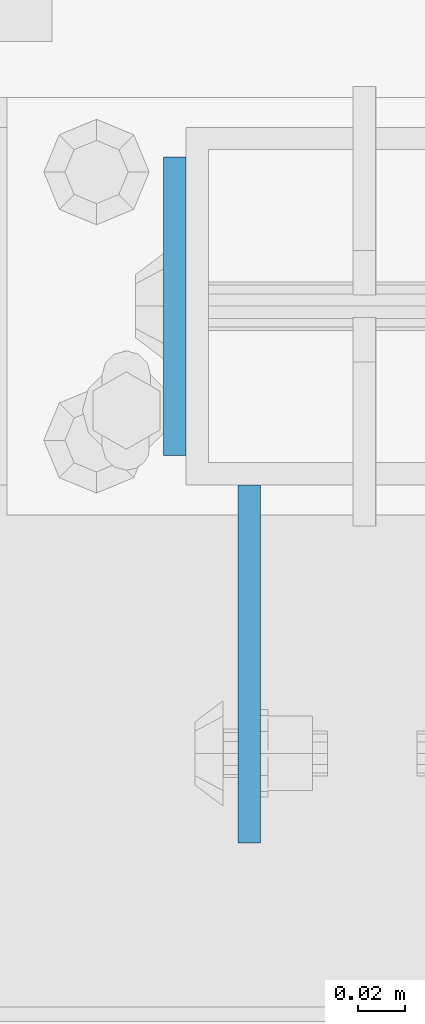
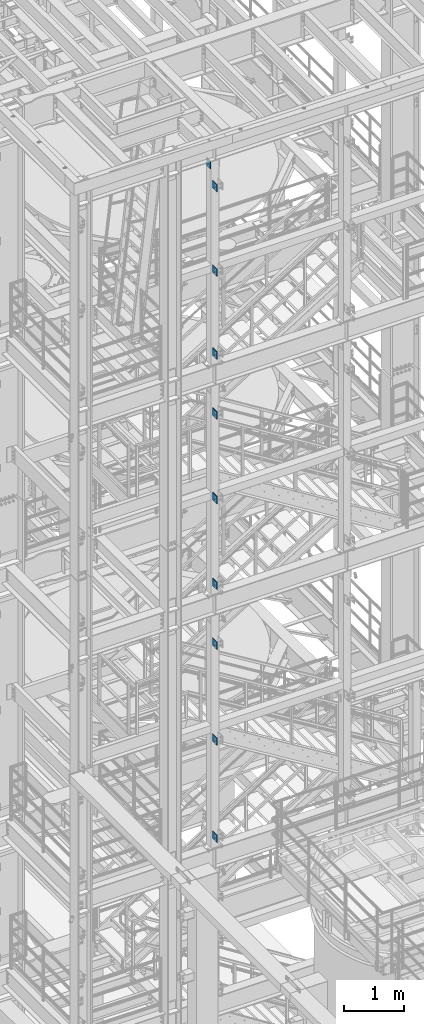
# One storey, part 1127 of 1876: 10 beams, 4 elements without a shape of their own.
"""IFC2X3 building model written with IfcOpenShell, lengths in millimetres."""

from ifc_helpers import new_model, si_unit, frame, origin_with_axes, place, context, subcontext, project, spatial, faceted_brep, material, type_object, element, aggregate, save


model = new_model("IFC2X3")

# Units and contexts
model_context = context("Model", 3, precision=1e-05, world=origin_with_axes())
body_context = subcontext(model_context, "Body", "Model", "MODEL_VIEW")
ifc_project = project(units=[si_unit("LENGTHUNIT", "METRE", prefix="MILLI"), si_unit("AREAUNIT", "SQUARE_METRE"), si_unit("VOLUMEUNIT", "CUBIC_METRE"), si_unit("MASSUNIT", "GRAM", prefix="KILO"), si_unit("TIMEUNIT", "SECOND"), si_unit("PLANEANGLEUNIT", "RADIAN"), si_unit("SOLIDANGLEUNIT", "STERADIAN"), si_unit("THERMODYNAMICTEMPERATUREUNIT", "DEGREE_CELSIUS"), si_unit("LUMINOUSINTENSITYUNIT", "LUMEN")], contexts=[model_context])

# Site, building, storey
site_placement = place(None, origin_with_axes())
site = spatial("IfcSite", under=ifc_project, at=site_placement, CompositionType="ELEMENT")
building_placement = place(site_placement, origin_with_axes())
building = spatial("IfcBuilding", under=site, at=building_placement, Name="Undefined", CompositionType="ELEMENT")
storey_placement = place(building_placement, origin_with_axes())
storey = spatial("IfcBuildingStorey", under=building, at=storey_placement, Name="Undefined", CompositionType="ELEMENT", Elevation=0.0)

# Assembly, beams
assembly_1_placement = place(storey_placement, origin_with_axes())
assembly_1 = element("IfcElementAssembly", 1, at=assembly_1_placement, inside=storey, Name="FRAME", AssemblyPlace="NOTDEFINED", PredefinedType="RIGID_FRAME")
ifc_material = material(Name="STEEL/A36")
beam_type_1 = type_object("IfcBeamType", PredefinedType="NOTDEFINED")
beam_1_placement = place(assembly_1_placement, frame((2490.7762944527, -7188.2, 21678.9), z_axis=(0.0, 0.0, -1.0), x_axis=(0.0, -1.0, 0.0)))
beam_1 = element("IfcBeam", 2, at=beam_1_placement, type_object=beam_type_1, material=ifc_material, Name="PLATE", context=body_context, shape_type="Brep", body=[
    faceted_brep([(0.0, 4.76249999999982, -76.1999999999998), (3.63797880709171e-12, 4.76249999999982, 76.1999969482422), (152.399993896484, 4.76250000000073, 76.1999969482422), (152.4, 4.76249999999982, -76.1999999999998), (3.63797880709171e-12, -4.76249999999982, 76.1999969482422), (152.399993896484, -4.76250000000073, 76.1999969482422), (0.0, -4.76249999999982, -76.1999999999998), (152.4, -4.76249999999982, -76.1999999999998)], [[[0, 1, 2, 3]], [[4, 5, 2, 1]], [[4, 6, 7, 5]], [[6, 0, 3, 7]], [[5, 7, 3, 2]], [[6, 4, 1, 0]]]),
])
beam_2_placement = place(assembly_1_placement, frame((2490.7762944527, -7188.2, 19958.05), z_axis=(0.0, 0.0, -1.0), x_axis=(0.0, -1.0, 0.0)))
beam_2 = element("IfcBeam", 3, at=beam_2_placement, type_object=beam_type_1, material=ifc_material, Name="PLATE", context=body_context, shape_type="Brep", body=[
    faceted_brep([(0.0, 4.76249999999982, -76.1999999999998), (3.63797880709171e-12, 4.76249999999982, 76.1999969482422), (152.399993896484, 4.76250000000073, 76.1999969482422), (152.4, 4.76249999999982, -76.1999999999998), (3.63797880709171e-12, -4.76249999999982, 76.1999969482422), (152.399993896484, -4.76250000000073, 76.1999969482422), (0.0, -4.76249999999982, -76.1999999999998), (152.4, -4.76249999999982, -76.1999999999998)], [[[0, 1, 2, 3]], [[4, 5, 2, 1]], [[4, 6, 7, 5]], [[6, 0, 3, 7]], [[5, 7, 3, 2]], [[6, 4, 1, 0]]]),
])
beam_3_placement = place(assembly_1_placement, frame((2490.7762944527, -7188.2, 18275.3), z_axis=(0.0, 0.0, -1.0), x_axis=(0.0, -1.0, 0.0)))
beam_3 = element("IfcBeam", 4, at=beam_3_placement, type_object=beam_type_1, material=ifc_material, Name="PLATE", context=body_context, shape_type="Brep", body=[
    faceted_brep([(0.0, 4.76249999999982, -76.1999999999998), (3.63797880709171e-12, 4.76249999999982, 76.1999969482422), (152.399993896484, 4.76250000000073, 76.1999969482422), (152.4, 4.76249999999982, -76.1999999999998), (3.63797880709171e-12, -4.76249999999982, 76.1999969482422), (152.399993896484, -4.76250000000073, 76.1999969482422), (0.0, -4.76249999999982, -76.1999999999998), (152.4, -4.76249999999982, -76.1999999999998)], [[[0, 1, 2, 3]], [[4, 5, 2, 1]], [[4, 6, 7, 5]], [[6, 0, 3, 7]], [[5, 7, 3, 2]], [[6, 4, 1, 0]]]),
])
aggregate(assembly_1, [beam_1, beam_2, beam_3])

assembly_2_placement = place(storey_placement, origin_with_axes())
assembly_2 = element("IfcElementAssembly", 5, at=assembly_2_placement, inside=storey, Name="FRAME", AssemblyPlace="NOTDEFINED", PredefinedType="RIGID_FRAME")
beam_4_placement = place(assembly_2_placement, frame((2490.7762944527, -7188.2, 17056.1), z_axis=(0.0, 0.0, -1.0), x_axis=(0.0, -1.0, 0.0)))
beam_4 = element("IfcBeam", 6, at=beam_4_placement, type_object=beam_type_1, material=ifc_material, Name="PLATE", context=body_context, shape_type="Brep", body=[
    faceted_brep([(0.0, 4.76249999999982, -76.1999999999998), (3.63797880709171e-12, 4.76249999999982, 76.1999969482422), (152.399993896484, 4.76250000000073, 76.1999969482422), (152.4, 4.76249999999982, -76.1999999999998), (3.63797880709171e-12, -4.76249999999982, 76.1999969482422), (152.399993896484, -4.76250000000073, 76.1999969482422), (0.0, -4.76249999999982, -76.1999999999998), (152.4, -4.76249999999982, -76.1999999999998)], [[[0, 1, 2, 3]], [[4, 5, 2, 1]], [[4, 6, 7, 5]], [[6, 0, 3, 7]], [[5, 7, 3, 2]], [[6, 4, 1, 0]]]),
])
beam_5_placement = place(assembly_2_placement, frame((2490.7762944527, -7188.2, 15335.25), z_axis=(0.0, 0.0, -1.0), x_axis=(0.0, -1.0, 0.0)))
beam_5 = element("IfcBeam", 7, at=beam_5_placement, type_object=beam_type_1, material=ifc_material, Name="PLATE", context=body_context, shape_type="Brep", body=[
    faceted_brep([(0.0, 4.76249999999982, -76.1999999999998), (3.63797880709171e-12, 4.76249999999982, 76.1999969482422), (152.399993896484, 4.76250000000073, 76.1999969482422), (152.4, 4.76249999999982, -76.1999999999998), (3.63797880709171e-12, -4.76249999999982, 76.1999969482422), (152.399993896484, -4.76250000000073, 76.1999969482422), (0.0, -4.76249999999982, -76.1999999999998), (152.4, -4.76249999999982, -76.1999999999998)], [[[0, 1, 2, 3]], [[4, 5, 2, 1]], [[4, 6, 7, 5]], [[6, 0, 3, 7]], [[5, 7, 3, 2]], [[6, 4, 1, 0]]]),
])
beam_6_placement = place(assembly_2_placement, frame((2490.7762944527, -7188.2, 13589.0), z_axis=(0.0, 0.0, -1.0), x_axis=(0.0, -1.0, 0.0)))
beam_6 = element("IfcBeam", 8, at=beam_6_placement, type_object=beam_type_1, material=ifc_material, Name="PLATE", context=body_context, shape_type="Brep", body=[
    faceted_brep([(0.0, 4.76249999999982, -76.1999999999998), (3.63797880709171e-12, 4.76249999999982, 76.1999969482422), (152.399993896484, 4.76250000000073, 76.1999969482422), (152.4, 4.76249999999982, -76.1999999999998), (3.63797880709171e-12, -4.76249999999982, 76.1999969482422), (152.399993896484, -4.76250000000073, 76.1999969482422), (0.0, -4.76249999999982, -76.1999999999998), (152.4, -4.76249999999982, -76.1999999999998)], [[[0, 1, 2, 3]], [[4, 5, 2, 1]], [[4, 6, 7, 5]], [[6, 0, 3, 7]], [[5, 7, 3, 2]], [[6, 4, 1, 0]]]),
])
aggregate(assembly_2, [beam_4, beam_5, beam_6])

assembly_3_placement = place(storey_placement, origin_with_axes())
assembly_3 = element("IfcElementAssembly", 9, at=assembly_3_placement, inside=storey, Name="FRAME", AssemblyPlace="NOTDEFINED", PredefinedType="RIGID_FRAME")
beam_7_placement = place(assembly_3_placement, frame((2490.7762944527, -7188.2, 12369.8), z_axis=(0.0, 0.0, -1.0), x_axis=(0.0, -1.0, 0.0)))
beam_7 = element("IfcBeam", 10, at=beam_7_placement, type_object=beam_type_1, material=ifc_material, Name="PLATE", context=body_context, shape_type="Brep", body=[
    faceted_brep([(0.0, 4.76249999999982, -76.1999999999998), (3.63797880709171e-12, 4.76249999999982, 76.1999969482422), (152.399993896484, 4.76250000000073, 76.1999969482422), (152.4, 4.76249999999982, -76.1999999999998), (3.63797880709171e-12, -4.76249999999982, 76.1999969482422), (152.399993896484, -4.76250000000073, 76.1999969482422), (0.0, -4.76249999999982, -76.1999999999998), (152.4, -4.76249999999982, -76.1999999999998)], [[[0, 1, 2, 3]], [[4, 5, 2, 1]], [[4, 6, 7, 5]], [[6, 0, 3, 7]], [[5, 7, 3, 2]], [[6, 4, 1, 0]]]),
])
beam_8_placement = place(assembly_3_placement, frame((2490.7762944527, -7188.2, 10420.35), z_axis=(0.0, 0.0, -1.0), x_axis=(0.0, -1.0, 0.0)))
beam_8 = element("IfcBeam", 11, at=beam_8_placement, type_object=beam_type_1, material=ifc_material, Name="PLATE", context=body_context, shape_type="Brep", body=[
    faceted_brep([(0.0, 4.76249999999982, -76.1999999999998), (3.63797880709171e-12, 4.76249999999982, 76.1999969482422), (152.399993896484, 4.76250000000073, 76.1999969482422), (152.4, 4.76249999999982, -76.1999999999998), (3.63797880709171e-12, -4.76249999999982, 76.1999969482422), (152.399993896484, -4.76250000000073, 76.1999969482422), (0.0, -4.76249999999982, -76.1999999999998), (152.4, -4.76249999999982, -76.1999999999998)], [[[0, 1, 2, 3]], [[4, 5, 2, 1]], [[4, 6, 7, 5]], [[6, 0, 3, 7]], [[5, 7, 3, 2]], [[6, 4, 1, 0]]]),
])
beam_9_placement = place(assembly_3_placement, frame((2490.7762944527, -7188.2, 8445.5), z_axis=(0.0, 0.0, -1.0), x_axis=(0.0, -1.0, 0.0)))
beam_9 = element("IfcBeam", 12, at=beam_9_placement, type_object=beam_type_1, material=ifc_material, Name="PLATE", context=body_context, shape_type="Brep", body=[
    faceted_brep([(0.0, 4.76249999999982, -76.1999999999998), (3.63797880709171e-12, 4.76249999999982, 76.1999969482422), (152.399993896484, 4.76250000000073, 76.1999969482422), (152.4, 4.76249999999982, -76.1999999999998), (3.63797880709171e-12, -4.76249999999982, 76.1999969482422), (152.399993896484, -4.76250000000073, 76.1999969482422), (0.0, -4.76249999999982, -76.1999999999998), (152.4, -4.76249999999982, -76.1999999999998)], [[[0, 1, 2, 3]], [[4, 5, 2, 1]], [[4, 6, 7, 5]], [[6, 0, 3, 7]], [[5, 7, 3, 2]], [[6, 4, 1, 0]]]),
])
aggregate(assembly_3, [beam_7, beam_8, beam_9])

# Assembly, beam
assembly_4_placement = place(storey_placement, origin_with_axes())
assembly_4 = element("IfcElementAssembly", 13, at=assembly_4_placement, inside=storey, Name="BEAM", AssemblyPlace="NOTDEFINED", PredefinedType="RIGID_FRAME")
beam_type_2 = type_object("IfcBeamType", PredefinedType="NOTDEFINED")
beam_10_placement = place(assembly_4_placement, frame((2459.0375, -7048.5, 22063.075), z_axis=(0.0, 0.0, -1.0), x_axis=(0.0, -1.0, 0.0)))
beam_10 = element("IfcBeam", 14, at=beam_10_placement, type_object=beam_type_2, material=ifc_material, Name="PLATE", context=body_context, shape_type="Brep", body=[
    faceted_brep([(0.0, 4.76249999999982, -82.5499999999993), (0.0, 4.76249999999982, 82.5499999999993), (127.0, 4.76249999999982, 82.5499999999993), (127.0, 4.76249999999982, -82.5499999999993), (0.0, -4.76249999999982, 82.5499999999993), (127.0, -4.76249999999982, 82.5499999999993), (0.0, -4.76249999999982, -82.5499999999993), (127.0, -4.76249999999982, -82.5499999999993)], [[[0, 1, 2, 3]], [[1, 4, 5, 2]], [[4, 6, 7, 5]], [[6, 0, 3, 7]], [[5, 7, 3, 2]], [[6, 4, 1, 0]]]),
])
aggregate(assembly_4, [beam_10])

save(model, "model.ifc")
